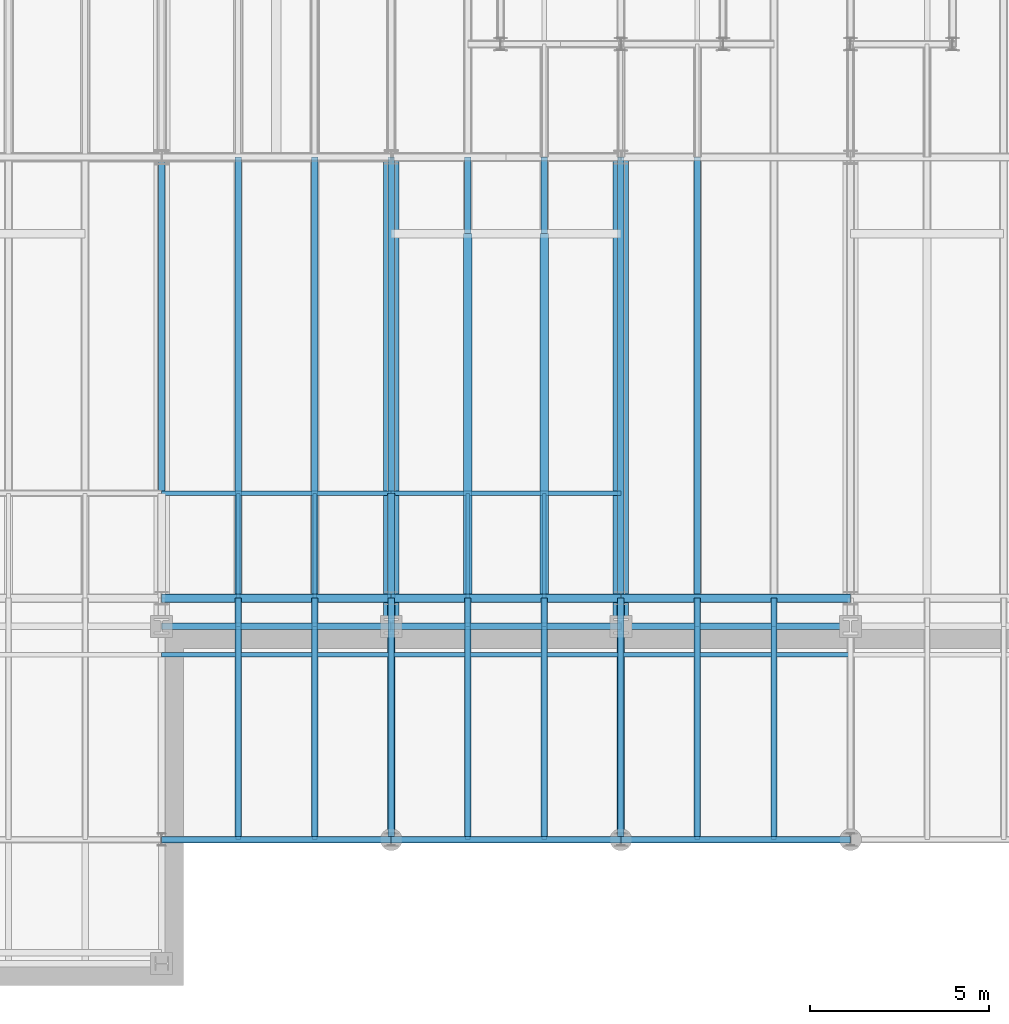
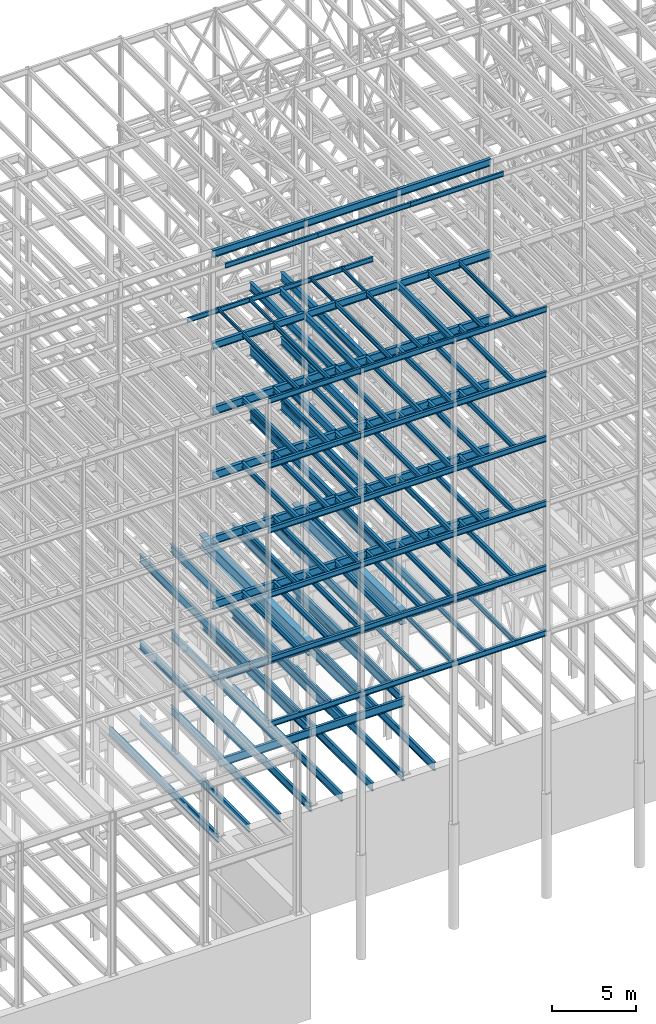
# One storey, part 130 of 150: 126 beams.
"""IFC2X3 building model written with IfcOpenShell, lengths in millimetres."""

from ifc_helpers import new_model, si_unit, frame, origin_with_axes, origin_2d_with_axis, place, context, subcontext, project, spatial, i_section, extrude, material, type_object, element, save


model = new_model("IFC2X3")

# Units and contexts
model_context = context("Model", 3, precision=1e-05, world=origin_with_axes())
body_context = subcontext(model_context, "Body", "Model", "MODEL_VIEW")
ifc_project = project(units=[si_unit("LENGTHUNIT", "METRE", prefix="MILLI"), si_unit("AREAUNIT", "SQUARE_METRE"), si_unit("VOLUMEUNIT", "CUBIC_METRE"), si_unit("MASSUNIT", "GRAM", prefix="KILO"), si_unit("TIMEUNIT", "SECOND"), si_unit("PLANEANGLEUNIT", "RADIAN"), si_unit("SOLIDANGLEUNIT", "STERADIAN"), si_unit("THERMODYNAMICTEMPERATUREUNIT", "DEGREE_CELSIUS"), si_unit("LUMINOUSINTENSITYUNIT", "LUMEN")], contexts=[model_context])

# Site, building, storey
site_placement = place(None, origin_with_axes())
site = spatial("IfcSite", under=ifc_project, at=site_placement, CompositionType="ELEMENT")
building_placement = place(site_placement, origin_with_axes())
building = spatial("IfcBuilding", under=site, at=building_placement, Name="Undefined", CompositionType="ELEMENT")
storey_placement = place(building_placement, origin_with_axes())
storey = spatial("IfcBuildingStorey", under=building, at=storey_placement, Name="Undefined", CompositionType="ELEMENT", Elevation=0.0)

# Beams
ifc_material = material(Name="STEEL/A992")
beam_type_1 = type_object("IfcBeamType", Name="W16X31", PredefinedType="NOTDEFINED")
for number, where, z_axis, x_axis, name in (
    (1, (56591.2, 3454.4, 59005.7875), (0.0, 0.0, 1.0), (1.0, 0.0, 0.0), "BEAM"),
    (2, (50190.4, 3454.4, 59005.7875), (0.0, 0.0, 1.0), (1.0, 0.0, 0.0), "BEAM"),
    (3, (43789.6, 3454.4, 59005.7875), (0.0, 0.0, 1.0), (1.0, 0.0, 0.0), "BEAM"),
):
    element("IfcBeam", number, at=place(storey_placement, frame(where, z_axis=z_axis, x_axis=x_axis)), inside=storey, type_object=beam_type_1, material=ifc_material, Name=name, ObjectType="W16X31", context=body_context, shape_type="SweptSolid", body=[
        extrude(i_section(OverallWidth=140.462, OverallDepth=403.225, WebThickness=6.3499, FlangeThickness=11.176, FilletRadius=17.399, at=origin_2d_with_axis()), frame((6400.80000000001, 0.0, 0.0), z_axis=(-1.0, 0.0, 0.0), x_axis=(0.0, -1.0, 0.0)), (0.0, 0.0, 1.0), 6400.8),
    ])
beam_type_2 = type_object("IfcBeamType", Name="W24X68", PredefinedType="NOTDEFINED")
for number, where, z_axis, x_axis, name in (
    (4, (54457.6, 10185.4, 54181.375), (0.0, 0.0, 1.0), (0.0, 1.0, 0.0), "BEAM"),
    (5, (52324.0, 10185.4, 54181.375), (0.0, 0.0, 1.0), (0.0, 1.0, 0.0), "BEAM"),
):
    element("IfcBeam", number, at=place(storey_placement, frame(where, z_axis=z_axis, x_axis=x_axis)), inside=storey, type_object=beam_type_2, material=ifc_material, Name=name, ObjectType="W24X68", context=body_context, shape_type="SweptSolid", body=[
        extrude(i_section(OverallWidth=227.838, OverallDepth=603.25, WebThickness=11.1125, FlangeThickness=14.859, FilletRadius=23.2409, at=origin_2d_with_axis()), frame((10160.0, 0.0, 0.0), z_axis=(-1.0, 0.0, 0.0), x_axis=(0.0, -1.0, 0.0)), (0.0, 0.0, 1.0), 10160.0),
    ])
for number, where, z_axis, x_axis, name in (
    (6, (56591.2, 10185.4, 54181.375), (0.0, 0.0, 1.0), (1.0, 0.0, 0.0), "BEAM"),
    (7, (50190.4, 10185.4, 54181.375), (0.0, 0.0, 1.0), (1.0, 0.0, 0.0), "BEAM"),
):
    element("IfcBeam", number, at=place(storey_placement, frame(where, z_axis=z_axis, x_axis=x_axis)), inside=storey, type_object=beam_type_2, material=ifc_material, Name=name, ObjectType="W24X68", context=body_context, shape_type="SweptSolid", body=[
        extrude(i_section(OverallWidth=227.838, OverallDepth=603.25, WebThickness=11.1125, FlangeThickness=14.859, FilletRadius=23.2409, at=origin_2d_with_axis()), frame((6400.80000000001, 0.0, 0.0), z_axis=(-1.0, 0.0, 0.0), x_axis=(0.0, -1.0, 0.0)), (0.0, 0.0, 1.0), 6400.8),
    ])
beam_1_placement = place(storey_placement, frame((43789.6, 10185.4, 54181.375), z_axis=(0.0, 0.0, 1.0), x_axis=(1.0, 0.0, 0.0)))
element("IfcBeam", 8, at=beam_1_placement, inside=storey, type_object=beam_type_2, material=ifc_material, Name="BEAM", ObjectType="W24X68", context=body_context, shape_type="SweptSolid", body=[
    extrude(i_section(OverallWidth=227.838, OverallDepth=603.25, WebThickness=11.1125, FlangeThickness=14.859, FilletRadius=23.2409, at=origin_2d_with_axis()), frame((6400.79935992001, 0.0, 0.0), z_axis=(-1.0, 0.0, 0.0), x_axis=(0.0, -1.0, 0.0)), (0.0, 0.0, 1.0), 6400.79935992),
])
for number, where, z_axis, x_axis, name in (
    (9, (54457.6, 10185.4, 49456.975), (0.0, 0.0, 1.0), (0.0, 1.0, 0.0), "BEAM"),
    (10, (52324.0, 10185.4, 49456.975), (0.0, 0.0, 1.0), (0.0, 1.0, 0.0), "BEAM"),
):
    element("IfcBeam", number, at=place(storey_placement, frame(where, z_axis=z_axis, x_axis=x_axis)), inside=storey, type_object=beam_type_2, material=ifc_material, Name=name, ObjectType="W24X68", context=body_context, shape_type="SweptSolid", body=[
        extrude(i_section(OverallWidth=227.838, OverallDepth=603.25, WebThickness=11.1125, FlangeThickness=14.859, FilletRadius=23.2409, at=origin_2d_with_axis()), frame((10160.0, 0.0, 0.0), z_axis=(-1.0, 0.0, 0.0), x_axis=(0.0, -1.0, 0.0)), (0.0, 0.0, 1.0), 10160.0),
    ])
for number, where, z_axis, x_axis, name in (
    (11, (56591.2, 10185.4, 49456.975), (0.0, 0.0, 1.0), (1.0, 0.0, 0.0), "BEAM"),
    (12, (50190.4, 10185.4, 49456.975), (0.0, 0.0, 1.0), (1.0, 0.0, 0.0), "BEAM"),
):
    element("IfcBeam", number, at=place(storey_placement, frame(where, z_axis=z_axis, x_axis=x_axis)), inside=storey, type_object=beam_type_2, material=ifc_material, Name=name, ObjectType="W24X68", context=body_context, shape_type="SweptSolid", body=[
        extrude(i_section(OverallWidth=227.838, OverallDepth=603.25, WebThickness=11.1125, FlangeThickness=14.859, FilletRadius=23.2409, at=origin_2d_with_axis()), frame((6400.80000000001, 0.0, 0.0), z_axis=(-1.0, 0.0, 0.0), x_axis=(0.0, -1.0, 0.0)), (0.0, 0.0, 1.0), 6400.8),
    ])
beam_2_placement = place(storey_placement, frame((43789.6, 10185.4, 49456.975), z_axis=(0.0, 0.0, 1.0), x_axis=(1.0, 0.0, 0.0)))
element("IfcBeam", 13, at=beam_2_placement, inside=storey, type_object=beam_type_2, material=ifc_material, Name="BEAM", ObjectType="W24X68", context=body_context, shape_type="SweptSolid", body=[
    extrude(i_section(OverallWidth=227.838, OverallDepth=603.25, WebThickness=11.1125, FlangeThickness=14.859, FilletRadius=23.2409, at=origin_2d_with_axis()), frame((6400.79935992001, 0.0, 0.0), z_axis=(-1.0, 0.0, 0.0), x_axis=(0.0, -1.0, 0.0)), (0.0, 0.0, 1.0), 6400.79935992),
])
for number, where, z_axis, x_axis, name in (
    (14, (54457.6, 10185.4, 44732.575), (0.0, 0.0, 1.0), (0.0, 1.0, 0.0), "BEAM"),
    (15, (52324.0, 10185.4, 44732.575), (0.0, 0.0, 1.0), (0.0, 1.0, 0.0), "BEAM"),
):
    element("IfcBeam", number, at=place(storey_placement, frame(where, z_axis=z_axis, x_axis=x_axis)), inside=storey, type_object=beam_type_2, material=ifc_material, Name=name, ObjectType="W24X68", context=body_context, shape_type="SweptSolid", body=[
        extrude(i_section(OverallWidth=227.838, OverallDepth=603.25, WebThickness=11.1125, FlangeThickness=14.859, FilletRadius=23.2409, at=origin_2d_with_axis()), frame((10160.0, 0.0, 0.0), z_axis=(-1.0, 0.0, 0.0), x_axis=(0.0, -1.0, 0.0)), (0.0, 0.0, 1.0), 10160.0),
    ])
for number, where, z_axis, x_axis, name in (
    (16, (56591.2, 10185.4, 44732.575), (0.0, 0.0, 1.0), (1.0, 0.0, 0.0), "BEAM"),
    (17, (50190.4, 10185.4, 44732.575), (0.0, 0.0, 1.0), (1.0, 0.0, 0.0), "BEAM"),
):
    element("IfcBeam", number, at=place(storey_placement, frame(where, z_axis=z_axis, x_axis=x_axis)), inside=storey, type_object=beam_type_2, material=ifc_material, Name=name, ObjectType="W24X68", context=body_context, shape_type="SweptSolid", body=[
        extrude(i_section(OverallWidth=227.838, OverallDepth=603.25, WebThickness=11.1125, FlangeThickness=14.859, FilletRadius=23.2409, at=origin_2d_with_axis()), frame((6400.80000000001, 0.0, 0.0), z_axis=(-1.0, 0.0, 0.0), x_axis=(0.0, -1.0, 0.0)), (0.0, 0.0, 1.0), 6400.8),
    ])
beam_3_placement = place(storey_placement, frame((43789.6, 10185.4, 44732.575), z_axis=(0.0, 0.0, 1.0), x_axis=(1.0, 0.0, 0.0)))
element("IfcBeam", 18, at=beam_3_placement, inside=storey, type_object=beam_type_2, material=ifc_material, Name="BEAM", ObjectType="W24X68", context=body_context, shape_type="SweptSolid", body=[
    extrude(i_section(OverallWidth=227.838, OverallDepth=603.25, WebThickness=11.1125, FlangeThickness=14.859, FilletRadius=23.2409, at=origin_2d_with_axis()), frame((6400.79935992001, 0.0, 0.0), z_axis=(-1.0, 0.0, 0.0), x_axis=(0.0, -1.0, 0.0)), (0.0, 0.0, 1.0), 6400.79935992),
])
for number, where, z_axis, x_axis, name in (
    (19, (56591.2, 10185.4, 40008.175), (0.0, 0.0, 1.0), (1.0, 0.0, 0.0), "BEAM"),
    (20, (50190.4, 10185.4, 40008.175), (0.0, 0.0, 1.0), (1.0, 0.0, 0.0), "BEAM"),
    (21, (43789.6, 10185.4, 40008.175), (0.0, 0.0, 1.0), (1.0, 0.0, 0.0), "BEAM"),
):
    element("IfcBeam", number, at=place(storey_placement, frame(where, z_axis=z_axis, x_axis=x_axis)), inside=storey, type_object=beam_type_2, material=ifc_material, Name=name, ObjectType="W24X68", context=body_context, shape_type="SweptSolid", body=[
        extrude(i_section(OverallWidth=227.838, OverallDepth=603.25, WebThickness=11.1125, FlangeThickness=14.859, FilletRadius=23.2409, at=origin_2d_with_axis()), frame((6400.80000000001, 0.0, 0.0), z_axis=(-1.0, 0.0, 0.0), x_axis=(0.0, -1.0, 0.0)), (0.0, 0.0, 1.0), 6400.8),
    ])
beam_type_3 = type_object("IfcBeamType", Name="W14X22", PredefinedType="NOTDEFINED")
for number, where, z_axis, x_axis, name in (
    (22, (56591.2, 8610.6, 65738.375), (0.0, 0.0, 1.0), (1.0, 0.0, 0.0), "BEAM"),
    (23, (50190.4, 8610.6, 65738.375), (0.0, 0.0, 1.0), (1.0, 0.0, 0.0), "BEAM"),
    (24, (43789.6, 8610.6, 65738.375), (0.0, 0.0, 1.0), (1.0, 0.0, 0.0), "BEAM"),
):
    element("IfcBeam", number, at=place(storey_placement, frame(where, z_axis=z_axis, x_axis=x_axis)), inside=storey, type_object=beam_type_3, material=ifc_material, Name=name, ObjectType="W14X22", context=body_context, shape_type="SweptSolid", body=[
        extrude(i_section(OverallWidth=127.0, OverallDepth=349.25, WebThickness=6.3499, FlangeThickness=8.509, FilletRadius=18.4785, at=origin_2d_with_axis()), frame((6400.80000000001, 0.0, 0.0), z_axis=(-1.0, 0.0, 0.0), x_axis=(0.0, -1.0, 0.0)), (0.0, 0.0, 1.0), 6400.8),
    ])
for number, where, z_axis, x_axis, name in (
    (25, (60858.4, 3454.4, 59032.775), (0.0, 0.0, 1.0), (0.0, 1.0, 0.0), "BEAM"),
    (26, (58724.8, 3454.4, 59032.775), (0.0, 0.0, 1.0), (0.0, 1.0, 0.0), "BEAM"),
):
    element("IfcBeam", number, at=place(storey_placement, frame(where, z_axis=z_axis, x_axis=x_axis)), inside=storey, type_object=beam_type_3, material=ifc_material, Name=name, ObjectType="W14X22", context=body_context, shape_type="SweptSolid", body=[
        extrude(i_section(OverallWidth=127.0, OverallDepth=349.25, WebThickness=6.3499, FlangeThickness=8.509, FilletRadius=18.4785, at=origin_2d_with_axis()), frame((6731.0, 0.0, 0.0), z_axis=(-1.0, 0.0, 0.0), x_axis=(0.0, -1.0, 0.0)), (0.0, 0.0, 1.0), 6731.0),
    ])
beam_4_placement = place(storey_placement, frame((50190.4, 13106.4, 59032.775), z_axis=(0.0, 0.0, 1.0), x_axis=(1.0, 0.0, 0.0)))
element("IfcBeam", 27, at=beam_4_placement, inside=storey, type_object=beam_type_3, material=ifc_material, Name="BEAM", ObjectType="W14X22", context=body_context, shape_type="SweptSolid", body=[
    extrude(i_section(OverallWidth=127.0, OverallDepth=349.25, WebThickness=6.3499, FlangeThickness=8.509, FilletRadius=18.4785, at=origin_2d_with_axis()), frame((6400.80000000001, 0.0, 0.0), z_axis=(-1.0, 0.0, 0.0), x_axis=(0.0, -1.0, 0.0)), (0.0, 0.0, 1.0), 6400.8),
])
for number, where, z_axis, x_axis, name in (
    (28, (54457.6, 3454.4, 59032.775), (0.0, 0.0, 1.0), (0.0, 1.0, 0.0), "BEAM"),
    (29, (52324.0, 3454.4, 59032.775), (0.0, 0.0, 1.0), (0.0, 1.0, 0.0), "BEAM"),
):
    element("IfcBeam", number, at=place(storey_placement, frame(where, z_axis=z_axis, x_axis=x_axis)), inside=storey, type_object=beam_type_3, material=ifc_material, Name=name, ObjectType="W14X22", context=body_context, shape_type="SweptSolid", body=[
        extrude(i_section(OverallWidth=127.0, OverallDepth=349.25, WebThickness=6.3499, FlangeThickness=8.509, FilletRadius=18.4785, at=origin_2d_with_axis()), frame((6731.0, 0.0, 0.0), z_axis=(-1.0, 0.0, 0.0), x_axis=(0.0, -1.0, 0.0)), (0.0, 0.0, 1.0), 6731.0),
    ])
beam_5_placement = place(storey_placement, frame((43789.6, 13106.4, 59032.775), z_axis=(0.0, 0.0, 1.0), x_axis=(1.0, 0.0, 0.0)))
element("IfcBeam", 30, at=beam_5_placement, inside=storey, type_object=beam_type_3, material=ifc_material, Name="BEAM", ObjectType="W14X22", context=body_context, shape_type="SweptSolid", body=[
    extrude(i_section(OverallWidth=127.0, OverallDepth=349.25, WebThickness=6.3499, FlangeThickness=8.509, FilletRadius=18.4785, at=origin_2d_with_axis()), frame((6400.80000000001, 0.0, 0.0), z_axis=(-1.0, 0.0, 0.0), x_axis=(0.0, -1.0, 0.0)), (0.0, 0.0, 1.0), 6400.8),
])
for number, where, z_axis, x_axis, name in (
    (31, (48056.8, 3454.4, 59032.775), (0.0, 0.0, 1.0), (0.0, 1.0, 0.0), "BEAM"),
    (32, (45923.2, 3454.4, 59032.775), (0.0, 0.0, 1.0), (0.0, 1.0, 0.0), "BEAM"),
):
    element("IfcBeam", number, at=place(storey_placement, frame(where, z_axis=z_axis, x_axis=x_axis)), inside=storey, type_object=beam_type_3, material=ifc_material, Name=name, ObjectType="W14X22", context=body_context, shape_type="SweptSolid", body=[
        extrude(i_section(OverallWidth=127.0, OverallDepth=349.25, WebThickness=6.3499, FlangeThickness=8.509, FilletRadius=18.4785, at=origin_2d_with_axis()), frame((6731.0, 0.0, 0.0), z_axis=(-1.0, 0.0, 0.0), x_axis=(0.0, -1.0, 0.0)), (0.0, 0.0, 1.0), 6731.0),
    ])
for number, where, z_axis, x_axis, name in (
    (33, (60858.4, 3454.4, 35410.775), (0.0, 0.0, 1.0), (0.0, 1.0, 0.0), "BEAM"),
    (34, (58724.8, 3454.4, 35410.775), (0.0, 0.0, 1.0), (0.0, 1.0, 0.0), "BEAM"),
    (35, (56591.2, 3454.4, 35410.775), (0.0, 0.0, 1.0), (0.0, 1.0, 0.0), "BEAM"),
    (36, (54457.6, 3454.4, 35410.775), (0.0, 0.0, 1.0), (0.0, 1.0, 0.0), "BEAM"),
    (37, (52324.0, 3454.4, 35410.775), (0.0, 0.0, 1.0), (0.0, 1.0, 0.0), "BEAM"),
    (38, (50190.4, 3454.4, 35410.775), (0.0, 0.0, 1.0), (0.0, 1.0, 0.0), "BEAM"),
    (39, (48056.8, 3454.4, 35410.775), (0.0, 0.0, 1.0), (0.0, 1.0, 0.0), "BEAM"),
    (40, (45923.2, 3454.4, 35410.775), (0.0, 0.0, 1.0), (0.0, 1.0, 0.0), "BEAM"),
):
    element("IfcBeam", number, at=place(storey_placement, frame(where, z_axis=z_axis, x_axis=x_axis)), inside=storey, type_object=beam_type_3, material=ifc_material, Name=name, ObjectType="W14X22", context=body_context, shape_type="SweptSolid", body=[
        extrude(i_section(OverallWidth=127.0, OverallDepth=349.25, WebThickness=6.3499, FlangeThickness=8.509, FilletRadius=18.4785, at=origin_2d_with_axis()), frame((5943.6, 0.0, 0.0), z_axis=(-1.0, 0.0, 0.0), x_axis=(0.0, -1.0, 0.0)), (0.0, 0.0, 1.0), 5943.6),
    ])
beam_type_4 = type_object("IfcBeamType", Name="W21X55", PredefinedType="NOTDEFINED")
for number, where, z_axis, x_axis, name in (
    (41, (56591.2, 10185.4, 65649.475), (0.0, 0.0, 1.0), (1.0, 0.0, 0.0), "BEAM"),
    (42, (50190.4, 10185.4, 65649.475), (0.0, 0.0, 1.0), (1.0, 0.0, 0.0), "BEAM"),
    (43, (43789.6, 10185.4, 65649.475), (0.0, 0.0, 1.0), (1.0, 0.0, 0.0), "BEAM"),
    (44, (56591.2, 10185.4, 58943.875), (0.0, 0.0, 1.0), (1.0, 0.0, 0.0), "BEAM"),
):
    element("IfcBeam", number, at=place(storey_placement, frame(where, z_axis=z_axis, x_axis=x_axis)), inside=storey, type_object=beam_type_4, material=ifc_material, Name=name, ObjectType="W21X55", context=body_context, shape_type="SweptSolid", body=[
        extrude(i_section(OverallWidth=208.788, OverallDepth=527.05, WebThickness=9.5, FlangeThickness=13.2588, FilletRadius=16.8624, at=origin_2d_with_axis()), frame((6400.80000000001, 0.0, 0.0), z_axis=(-1.0, 0.0, 0.0), x_axis=(0.0, -1.0, 0.0)), (0.0, 0.0, 1.0), 6400.8),
    ])
beam_6_placement = place(storey_placement, frame((56591.2, 3454.4, 58943.875), z_axis=(0.0, 0.0, 1.0), x_axis=(0.0, 1.0, 0.0)))
element("IfcBeam", 45, at=beam_6_placement, inside=storey, type_object=beam_type_4, material=ifc_material, Name="BEAM", ObjectType="W21X55", context=body_context, shape_type="SweptSolid", body=[
    extrude(i_section(OverallWidth=208.788, OverallDepth=527.05, WebThickness=9.5, FlangeThickness=13.2588, FilletRadius=16.8624, at=origin_2d_with_axis()), frame((6731.0, 0.0, 0.0), z_axis=(-1.0, 0.0, 0.0), x_axis=(0.0, -1.0, 0.0)), (0.0, 0.0, 1.0), 6731.0),
])
beam_7_placement = place(storey_placement, frame((50190.4, 10185.4, 58943.875), z_axis=(0.0, 0.0, 1.0), x_axis=(1.0, 0.0, 0.0)))
element("IfcBeam", 46, at=beam_7_placement, inside=storey, type_object=beam_type_4, material=ifc_material, Name="BEAM", ObjectType="W21X55", context=body_context, shape_type="SweptSolid", body=[
    extrude(i_section(OverallWidth=208.788, OverallDepth=527.05, WebThickness=9.5, FlangeThickness=13.2588, FilletRadius=16.8624, at=origin_2d_with_axis()), frame((6400.80000000001, 0.0, 0.0), z_axis=(-1.0, 0.0, 0.0), x_axis=(0.0, -1.0, 0.0)), (0.0, 0.0, 1.0), 6400.8),
])
beam_8_placement = place(storey_placement, frame((50190.4, 10185.4, 58943.875), z_axis=(0.0, 0.0, 1.0), x_axis=(0.0, 1.0, 0.0)))
element("IfcBeam", 47, at=beam_8_placement, inside=storey, type_object=beam_type_4, material=ifc_material, Name="BEAM", ObjectType="W21X55", context=body_context, shape_type="SweptSolid", body=[
    extrude(i_section(OverallWidth=208.788, OverallDepth=527.05, WebThickness=9.5, FlangeThickness=13.2588, FilletRadius=16.8624, at=origin_2d_with_axis()), frame((2921.0, 0.0, 0.0), z_axis=(-1.0, 0.0, 0.0), x_axis=(0.0, -1.0, 0.0)), (0.0, 0.0, 1.0), 2921.0),
])
beam_9_placement = place(storey_placement, frame((50190.4, 3454.4, 58943.875), z_axis=(0.0, 0.0, 1.0), x_axis=(0.0, 1.0, 0.0)))
element("IfcBeam", 48, at=beam_9_placement, inside=storey, type_object=beam_type_4, material=ifc_material, Name="BEAM", ObjectType="W21X55", context=body_context, shape_type="SweptSolid", body=[
    extrude(i_section(OverallWidth=208.788, OverallDepth=527.05, WebThickness=9.5, FlangeThickness=13.2588, FilletRadius=16.8624, at=origin_2d_with_axis()), frame((6731.0, 0.0, 0.0), z_axis=(-1.0, 0.0, 0.0), x_axis=(0.0, -1.0, 0.0)), (0.0, 0.0, 1.0), 6731.0),
])
beam_10_placement = place(storey_placement, frame((43789.6, 10185.4, 58943.875), z_axis=(0.0, 0.0, 1.0), x_axis=(1.0, 0.0, 0.0)))
element("IfcBeam", 49, at=beam_10_placement, inside=storey, type_object=beam_type_4, material=ifc_material, Name="BEAM", ObjectType="W21X55", context=body_context, shape_type="SweptSolid", body=[
    extrude(i_section(OverallWidth=208.788, OverallDepth=527.05, WebThickness=9.5, FlangeThickness=13.2588, FilletRadius=16.8624, at=origin_2d_with_axis()), frame((6400.80000000001, 0.0, 0.0), z_axis=(-1.0, 0.0, 0.0), x_axis=(0.0, -1.0, 0.0)), (0.0, 0.0, 1.0), 6400.8),
])
beam_type_5 = type_object("IfcBeamType", Name="W10X15", PredefinedType="NOTDEFINED")
for number, where, z_axis, x_axis, name in (
    (50, (54457.6, 10185.4, 59080.4), (0.0, 0.0, 1.0), (0.0, 1.0, 0.0), "BEAM"),
    (51, (52324.0, 10185.4, 59080.4), (0.0, 0.0, 1.0), (0.0, 1.0, 0.0), "BEAM"),
    (52, (48056.8, 10185.4, 59080.4), (0.0, 0.0, 1.0), (0.0, 1.0, 0.0), "BEAM"),
    (53, (45923.2, 10185.4, 59080.4), (0.0, 0.0, 1.0), (0.0, 1.0, 0.0), "BEAM"),
):
    element("IfcBeam", number, at=place(storey_placement, frame(where, z_axis=z_axis, x_axis=x_axis)), inside=storey, type_object=beam_type_5, material=ifc_material, Name=name, ObjectType="W10X15", context=body_context, shape_type="SweptSolid", body=[
        extrude(i_section(OverallWidth=101.6, OverallDepth=254.0, WebThickness=6.3499, FlangeThickness=6.858, FilletRadius=13.7795, at=origin_2d_with_axis()), frame((2921.0, 0.0, 0.0), z_axis=(-1.0, 0.0, 0.0), x_axis=(0.0, -1.0, 0.0)), (0.0, 0.0, 1.0), 2921.0),
    ])
beam_type_6 = type_object("IfcBeamType", Name="W24X55", PredefinedType="NOTDEFINED")
for number, where, z_axis, x_axis, name in (
    (54, (56591.2, 9398.0, 35285.3625), (0.0, 0.0, 1.0), (1.0, 0.0, 0.0), "BEAM"),
    (55, (50190.4, 9398.0, 35285.3625), (0.0, 0.0, 1.0), (1.0, 0.0, 0.0), "BEAM"),
    (56, (43789.6, 9398.0, 35285.3625), (0.0, 0.0, 1.0), (1.0, 0.0, 0.0), "BEAM"),
):
    element("IfcBeam", number, at=place(storey_placement, frame(where, z_axis=z_axis, x_axis=x_axis)), inside=storey, type_object=beam_type_6, material=ifc_material, Name=name, ObjectType="W24X55", context=body_context, shape_type="SweptSolid", body=[
        extrude(i_section(OverallWidth=178.054, OverallDepth=600.075, WebThickness=9.5249, FlangeThickness=12.827, FilletRadius=23.6854, at=origin_2d_with_axis()), frame((6400.80000000001, 0.0, 0.0), z_axis=(-1.0, 0.0, 0.0), x_axis=(0.0, -1.0, 0.0)), (0.0, 0.0, 1.0), 6400.8),
    ])
beam_type_7 = type_object("IfcBeamType", Name="W16X36", PredefinedType="NOTDEFINED")
for number, where, z_axis, x_axis, name in (
    (57, (56591.2, 3454.4, 54281.3875), (0.0, 0.0, 1.0), (1.0, 0.0, 0.0), "BEAM"),
    (58, (50190.4, 3454.4, 54281.3875), (0.0, 0.0, 1.0), (1.0, 0.0, 0.0), "BEAM"),
    (59, (43789.6, 3454.4, 54281.3875), (0.0, 0.0, 1.0), (1.0, 0.0, 0.0), "BEAM"),
):
    element("IfcBeam", number, at=place(storey_placement, frame(where, z_axis=z_axis, x_axis=x_axis)), inside=storey, type_object=beam_type_7, material=ifc_material, Name=name, ObjectType="W16X36", context=body_context, shape_type="SweptSolid", body=[
        extrude(i_section(OverallWidth=177.8, OverallDepth=403.225, WebThickness=7.9375, FlangeThickness=10.922, FilletRadius=17.6529, at=origin_2d_with_axis()), frame((6400.80000000001, 0.0, 0.0), z_axis=(-1.0, 0.0, 0.0), x_axis=(0.0, -1.0, 0.0)), (0.0, 0.0, 1.0), 6400.8),
    ])
for number, where, z_axis, x_axis, name in (
    (60, (60858.4, 3454.4, 54281.3875), (0.0, 0.0, 1.0), (0.0, 1.0, 0.0), "BEAM"),
    (61, (58724.8, 3454.4, 54281.3875), (0.0, 0.0, 1.0), (0.0, 1.0, 0.0), "BEAM"),
    (62, (56591.2, 3454.4, 54281.3875), (0.0, 0.0, 1.0), (0.0, 1.0, 0.0), "BEAM"),
    (63, (54457.6, 3454.4, 54281.3875), (0.0, 0.0, 1.0), (0.0, 1.0, 0.0), "BEAM"),
    (64, (52324.0, 3454.4, 54281.3875), (0.0, 0.0, 1.0), (0.0, 1.0, 0.0), "BEAM"),
    (65, (50190.4, 3454.4, 54281.3875), (0.0, 0.0, 1.0), (0.0, 1.0, 0.0), "BEAM"),
    (66, (48056.8, 3454.4, 54281.3875), (0.0, 0.0, 1.0), (0.0, 1.0, 0.0), "BEAM"),
    (67, (45923.2, 3454.4, 54281.3875), (0.0, 0.0, 1.0), (0.0, 1.0, 0.0), "BEAM"),
):
    element("IfcBeam", number, at=place(storey_placement, frame(where, z_axis=z_axis, x_axis=x_axis)), inside=storey, type_object=beam_type_7, material=ifc_material, Name=name, ObjectType="W16X36", context=body_context, shape_type="SweptSolid", body=[
        extrude(i_section(OverallWidth=177.8, OverallDepth=403.225, WebThickness=7.9375, FlangeThickness=10.922, FilletRadius=17.6529, at=origin_2d_with_axis()), frame((6731.0, 0.0, 0.0), z_axis=(-1.0, 0.0, 0.0), x_axis=(0.0, -1.0, 0.0)), (0.0, 0.0, 1.0), 6731.0),
    ])
for number, where, z_axis, x_axis, name in (
    (68, (56591.2, 3454.4, 49556.9875), (0.0, 0.0, 1.0), (1.0, 0.0, 0.0), "BEAM"),
    (69, (50190.4, 3454.4, 49556.9875), (0.0, 0.0, 1.0), (1.0, 0.0, 0.0), "BEAM"),
    (70, (43789.6, 3454.4, 49556.9875), (0.0, 0.0, 1.0), (1.0, 0.0, 0.0), "BEAM"),
):
    element("IfcBeam", number, at=place(storey_placement, frame(where, z_axis=z_axis, x_axis=x_axis)), inside=storey, type_object=beam_type_7, material=ifc_material, Name=name, ObjectType="W16X36", context=body_context, shape_type="SweptSolid", body=[
        extrude(i_section(OverallWidth=177.8, OverallDepth=403.225, WebThickness=7.9375, FlangeThickness=10.922, FilletRadius=17.6529, at=origin_2d_with_axis()), frame((6400.80000000001, 0.0, 0.0), z_axis=(-1.0, 0.0, 0.0), x_axis=(0.0, -1.0, 0.0)), (0.0, 0.0, 1.0), 6400.8),
    ])
for number, where, z_axis, x_axis, name in (
    (71, (60858.4, 3454.4, 49556.9875), (0.0, 0.0, 1.0), (0.0, 1.0, 0.0), "BEAM"),
    (72, (58724.8, 3454.4, 49556.9875), (0.0, 0.0, 1.0), (0.0, 1.0, 0.0), "BEAM"),
    (73, (56591.2, 3454.4, 49556.9875), (0.0, 0.0, 1.0), (0.0, 1.0, 0.0), "BEAM"),
    (74, (54457.6, 3454.4, 49556.9875), (0.0, 0.0, 1.0), (0.0, 1.0, 0.0), "BEAM"),
    (75, (52324.0, 3454.4, 49556.9875), (0.0, 0.0, 1.0), (0.0, 1.0, 0.0), "BEAM"),
    (76, (50190.4, 3454.4, 49556.9875), (0.0, 0.0, 1.0), (0.0, 1.0, 0.0), "BEAM"),
    (77, (48056.8, 3454.4, 49556.9875), (0.0, 0.0, 1.0), (0.0, 1.0, 0.0), "BEAM"),
    (78, (45923.2, 3454.4, 49556.9875), (0.0, 0.0, 1.0), (0.0, 1.0, 0.0), "BEAM"),
):
    element("IfcBeam", number, at=place(storey_placement, frame(where, z_axis=z_axis, x_axis=x_axis)), inside=storey, type_object=beam_type_7, material=ifc_material, Name=name, ObjectType="W16X36", context=body_context, shape_type="SweptSolid", body=[
        extrude(i_section(OverallWidth=177.8, OverallDepth=403.225, WebThickness=7.9375, FlangeThickness=10.922, FilletRadius=17.6529, at=origin_2d_with_axis()), frame((6731.0, 0.0, 0.0), z_axis=(-1.0, 0.0, 0.0), x_axis=(0.0, -1.0, 0.0)), (0.0, 0.0, 1.0), 6731.0),
    ])
for number, where, z_axis, x_axis, name in (
    (79, (56591.2, 3454.4, 44832.5875), (0.0, 0.0, 1.0), (1.0, 0.0, 0.0), "BEAM"),
    (80, (50190.4, 3454.4, 44832.5875), (0.0, 0.0, 1.0), (1.0, 0.0, 0.0), "BEAM"),
    (81, (43789.6, 3454.4, 44832.5875), (0.0, 0.0, 1.0), (1.0, 0.0, 0.0), "BEAM"),
):
    element("IfcBeam", number, at=place(storey_placement, frame(where, z_axis=z_axis, x_axis=x_axis)), inside=storey, type_object=beam_type_7, material=ifc_material, Name=name, ObjectType="W16X36", context=body_context, shape_type="SweptSolid", body=[
        extrude(i_section(OverallWidth=177.8, OverallDepth=403.225, WebThickness=7.9375, FlangeThickness=10.922, FilletRadius=17.6529, at=origin_2d_with_axis()), frame((6400.80000000001, 0.0, 0.0), z_axis=(-1.0, 0.0, 0.0), x_axis=(0.0, -1.0, 0.0)), (0.0, 0.0, 1.0), 6400.8),
    ])
for number, where, z_axis, x_axis, name in (
    (82, (60858.4, 3454.4, 44832.5875), (0.0, 0.0, 1.0), (0.0, 1.0, 0.0), "BEAM"),
    (83, (58724.8, 3454.4, 44832.5875), (0.0, 0.0, 1.0), (0.0, 1.0, 0.0), "BEAM"),
    (84, (56591.2, 3454.4, 44832.5875), (0.0, 0.0, 1.0), (0.0, 1.0, 0.0), "BEAM"),
    (85, (54457.6, 3454.4, 44832.5875), (0.0, 0.0, 1.0), (0.0, 1.0, 0.0), "BEAM"),
    (86, (52324.0, 3454.4, 44832.5875), (0.0, 0.0, 1.0), (0.0, 1.0, 0.0), "BEAM"),
    (87, (50190.4, 3454.4, 44832.5875), (0.0, 0.0, 1.0), (0.0, 1.0, 0.0), "BEAM"),
    (88, (48056.8, 3454.4, 44832.5875), (0.0, 0.0, 1.0), (0.0, 1.0, 0.0), "BEAM"),
    (89, (45923.2, 3454.4, 44832.5875), (0.0, 0.0, 1.0), (0.0, 1.0, 0.0), "BEAM"),
):
    element("IfcBeam", number, at=place(storey_placement, frame(where, z_axis=z_axis, x_axis=x_axis)), inside=storey, type_object=beam_type_7, material=ifc_material, Name=name, ObjectType="W16X36", context=body_context, shape_type="SweptSolid", body=[
        extrude(i_section(OverallWidth=177.8, OverallDepth=403.225, WebThickness=7.9375, FlangeThickness=10.922, FilletRadius=17.6529, at=origin_2d_with_axis()), frame((6731.0, 0.0, 0.0), z_axis=(-1.0, 0.0, 0.0), x_axis=(0.0, -1.0, 0.0)), (0.0, 0.0, 1.0), 6731.0),
    ])
for number, where, z_axis, x_axis, name in (
    (90, (56591.2, 3454.4, 40108.1875), (0.0, 0.0, 1.0), (1.0, 0.0, 0.0), "BEAM"),
    (91, (50190.4, 3454.4, 40108.1875), (0.0, 0.0, 1.0), (1.0, 0.0, 0.0), "BEAM"),
    (92, (43789.6, 3454.4, 40108.1875), (0.0, 0.0, 1.0), (1.0, 0.0, 0.0), "BEAM"),
):
    element("IfcBeam", number, at=place(storey_placement, frame(where, z_axis=z_axis, x_axis=x_axis)), inside=storey, type_object=beam_type_7, material=ifc_material, Name=name, ObjectType="W16X36", context=body_context, shape_type="SweptSolid", body=[
        extrude(i_section(OverallWidth=177.8, OverallDepth=403.225, WebThickness=7.9375, FlangeThickness=10.922, FilletRadius=17.6529, at=origin_2d_with_axis()), frame((6400.80000000001, 0.0, 0.0), z_axis=(-1.0, 0.0, 0.0), x_axis=(0.0, -1.0, 0.0)), (0.0, 0.0, 1.0), 6400.8),
    ])
for number, where, z_axis, x_axis, name in (
    (93, (60858.4, 3454.4, 40108.1875), (0.0, 0.0, 1.0), (0.0, 1.0, 0.0), "BEAM"),
    (94, (58724.8, 3454.4, 40108.1875), (0.0, 0.0, 1.0), (0.0, 1.0, 0.0), "BEAM"),
    (95, (56591.2, 3454.4, 40108.1875), (0.0, 0.0, 1.0), (0.0, 1.0, 0.0), "BEAM"),
    (96, (54457.6, 3454.4, 40108.1875), (0.0, 0.0, 1.0), (0.0, 1.0, 0.0), "BEAM"),
    (97, (52324.0, 3454.4, 40108.1875), (0.0, 0.0, 1.0), (0.0, 1.0, 0.0), "BEAM"),
    (98, (50190.4, 3454.4, 40108.1875), (0.0, 0.0, 1.0), (0.0, 1.0, 0.0), "BEAM"),
    (99, (48056.8, 3454.4, 40108.1875), (0.0, 0.0, 1.0), (0.0, 1.0, 0.0), "BEAM"),
    (100, (45923.2, 3454.4, 40108.1875), (0.0, 0.0, 1.0), (0.0, 1.0, 0.0), "BEAM"),
):
    element("IfcBeam", number, at=place(storey_placement, frame(where, z_axis=z_axis, x_axis=x_axis)), inside=storey, type_object=beam_type_7, material=ifc_material, Name=name, ObjectType="W16X36", context=body_context, shape_type="SweptSolid", body=[
        extrude(i_section(OverallWidth=177.8, OverallDepth=403.225, WebThickness=7.9375, FlangeThickness=10.922, FilletRadius=17.6529, at=origin_2d_with_axis()), frame((6731.0, 0.0, 0.0), z_axis=(-1.0, 0.0, 0.0), x_axis=(0.0, -1.0, 0.0)), (0.0, 0.0, 1.0), 6731.0),
    ])
beam_11_placement = place(storey_placement, frame((56591.2, 3454.4, 35383.7875), z_axis=(0.0, 0.0, 1.0), x_axis=(1.0, 0.0, 0.0)))
element("IfcBeam", 101, at=beam_11_placement, inside=storey, type_object=beam_type_7, material=ifc_material, Name="BEAM", ObjectType="W16X36", context=body_context, shape_type="SweptSolid", body=[
    extrude(i_section(OverallWidth=177.8, OverallDepth=403.225, WebThickness=7.9375, FlangeThickness=10.922, FilletRadius=17.6529, at=origin_2d_with_axis()), frame((6400.80000000001, 0.0, 0.0), z_axis=(-1.0, 0.0, 0.0), x_axis=(0.0, -1.0, 0.0)), (0.0, 0.0, 1.0), 6400.80000000001),
])
for number, where, z_axis, x_axis, name in (
    (102, (50190.4, 3454.4, 35383.7875), (0.0, 0.0, 1.0), (1.0, 0.0, 0.0), "BEAM"),
    (103, (43789.6, 3454.4, 35383.7875), (0.0, 0.0, 1.0), (1.0, 0.0, 0.0), "BEAM"),
):
    element("IfcBeam", number, at=place(storey_placement, frame(where, z_axis=z_axis, x_axis=x_axis)), inside=storey, type_object=beam_type_7, material=ifc_material, Name=name, ObjectType="W16X36", context=body_context, shape_type="SweptSolid", body=[
        extrude(i_section(OverallWidth=177.8, OverallDepth=403.225, WebThickness=7.9375, FlangeThickness=10.922, FilletRadius=17.6529, at=origin_2d_with_axis()), frame((6400.80000000001, 0.0, 0.0), z_axis=(-1.0, 0.0, 0.0), x_axis=(0.0, -1.0, 0.0)), (0.0, 0.0, 1.0), 6400.8),
    ])
beam_type_8 = type_object("IfcBeamType", Name="W24X62", PredefinedType="NOTDEFINED")
for number, where, z_axis, x_axis, name in (
    (104, (58724.8, 9398.0, 35283.775), (0.0, 0.0, 1.0), (0.0, 1.0, 0.0), "BEAM"),
    (105, (54457.6, 9398.0, 35283.775), (0.0, 0.0, 1.0), (0.0, 1.0, 0.0), "BEAM"),
    (106, (52324.0, 9398.0, 35283.775), (0.0, 0.0, 1.0), (0.0, 1.0, 0.0), "BEAM"),
    (107, (48056.8, 9398.0, 35283.775), (0.0, 0.0, 1.0), (0.0, 1.0, 0.0), "BEAM"),
    (108, (45923.2, 9398.0, 35283.775), (0.0, 0.0, 1.0), (0.0, 1.0, 0.0), "BEAM"),
    (109, (56591.2, 9398.0, 28984.575), (0.0, 0.0, 1.0), (0.0, 1.0, 0.0), "BEAM"),
    (110, (54457.6, 9398.0, 28984.575), (0.0, 0.0, 1.0), (0.0, 1.0, 0.0), "BEAM"),
    (111, (52324.0, 9398.0, 28984.575), (0.0, 0.0, 1.0), (0.0, 1.0, 0.0), "BEAM"),
    (112, (50190.4, 9398.0, 28984.575), (0.0, 0.0, 1.0), (0.0, 1.0, 0.0), "BEAM"),
    (113, (48056.8, 9398.0, 28984.575), (0.0, 0.0, 1.0), (0.0, 1.0, 0.0), "BEAM"),
    (114, (45923.2, 9398.0, 28984.575), (0.0, 0.0, 1.0), (0.0, 1.0, 0.0), "BEAM"),
):
    element("IfcBeam", number, at=place(storey_placement, frame(where, z_axis=z_axis, x_axis=x_axis)), inside=storey, type_object=beam_type_8, material=ifc_material, Name=name, ObjectType="W24X62", context=body_context, shape_type="SweptSolid", body=[
        extrude(i_section(OverallWidth=177.8, OverallDepth=603.25, WebThickness=11.1125, FlangeThickness=14.986, FilletRadius=23.114, at=origin_2d_with_axis()), frame((13081.0, 0.0, 0.0), z_axis=(-1.0, 0.0, 0.0), x_axis=(0.0, -1.0, 0.0)), (0.0, 0.0, 1.0), 13081.0),
    ])
beam_12_placement = place(storey_placement, frame((50190.4, 9398.0, 28984.575), z_axis=(0.0, 0.0, 1.0), x_axis=(1.0, 0.0, 0.0)))
element("IfcBeam", 115, at=beam_12_placement, inside=storey, type_object=beam_type_8, material=ifc_material, Name="BEAM", ObjectType="W24X62", context=body_context, shape_type="SweptSolid", body=[
    extrude(i_section(OverallWidth=177.8, OverallDepth=603.25, WebThickness=11.1125, FlangeThickness=14.986, FilletRadius=23.114, at=origin_2d_with_axis()), frame((6400.80000000001, 0.0, 0.0), z_axis=(-1.0, 0.0, 0.0), x_axis=(0.0, -1.0, 0.0)), (0.0, 0.0, 1.0), 6400.8),
])
beam_13_placement = place(storey_placement, frame((43789.6, 9398.0, 28984.575), z_axis=(0.0, 0.0, 1.0), x_axis=(1.0, 0.0, 0.0)))
element("IfcBeam", 116, at=beam_13_placement, inside=storey, type_object=beam_type_8, material=ifc_material, Name="BEAM", ObjectType="W24X62", context=body_context, shape_type="SweptSolid", body=[
    extrude(i_section(OverallWidth=177.8, OverallDepth=603.25, WebThickness=11.1125, FlangeThickness=14.986, FilletRadius=23.114, at=origin_2d_with_axis()), frame((6400.80000000001, 0.0, 0.0), z_axis=(-1.0, 0.0, 0.0), x_axis=(0.0, -1.0, 0.0)), (0.0, 0.0, 1.0), 6400.80000000001),
])
for number, where, z_axis, x_axis, name in (
    (117, (48056.8, 9398.0, 23472.775), (0.0, 0.0, 1.0), (0.0, 1.0, 0.0), "BEAM"),
    (118, (45923.2, 9398.0, 23472.775), (0.0, 0.0, 1.0), (0.0, 1.0, 0.0), "BEAM"),
    (119, (58724.8, 9398.0, 23472.775), (0.0, 0.0, 1.0), (0.0, 1.0, 0.0), "BEAM"),
    (120, (56591.2, 9398.0, 23472.775), (0.0, 0.0, 1.0), (0.0, 1.0, 0.0), "BEAM"),
    (121, (54457.6, 9398.0, 23472.775), (0.0, 0.0, 1.0), (0.0, 1.0, 0.0), "BEAM"),
    (122, (52324.0, 9398.0, 23472.775), (0.0, 0.0, 1.0), (0.0, 1.0, 0.0), "BEAM"),
    (123, (50190.4, 9398.0, 23472.775), (0.0, 0.0, 1.0), (0.0, 1.0, 0.0), "BEAM"),
    (124, (43789.6, 9398.0, 23472.775), (0.0, 0.0, 1.0), (0.0, 1.0, 0.0), "BEAM"),
):
    element("IfcBeam", number, at=place(storey_placement, frame(where, z_axis=z_axis, x_axis=x_axis)), inside=storey, type_object=beam_type_8, material=ifc_material, Name=name, ObjectType="W24X62", context=body_context, shape_type="SweptSolid", body=[
        extrude(i_section(OverallWidth=177.8, OverallDepth=603.25, WebThickness=11.1125, FlangeThickness=14.986, FilletRadius=23.114, at=origin_2d_with_axis()), frame((13081.0, 0.0, 0.0), z_axis=(-1.0, 0.0, 0.0), x_axis=(0.0, -1.0, 0.0)), (0.0, 0.0, 1.0), 13081.0),
    ])
beam_type_9 = type_object("IfcBeamType", Name="W36X395", PredefinedType="NOTDEFINED")
for number, where, z_axis, x_axis, name in (
    (125, (56591.2, 9398.0, 35098.0375), (0.0, 0.0, 1.0), (0.0, 1.0, 0.0), "BEAM"),
    (126, (50190.4, 9398.0, 35098.0375), (0.0, 0.0, 1.0), (0.0, 1.0, 0.0), "BEAM"),
):
    element("IfcBeam", number, at=place(storey_placement, frame(where, z_axis=z_axis, x_axis=x_axis)), inside=storey, type_object=beam_type_9, material=ifc_material, Name=name, ObjectType="W36X395", context=body_context, shape_type="SweptSolid", body=[
        extrude(i_section(OverallWidth=428.625, OverallDepth=974.725, WebThickness=30.988, FlangeThickness=55.88, FilletRadius=31.4324, at=origin_2d_with_axis()), frame((13081.0, 0.0, 0.0), z_axis=(-1.0, 0.0, 0.0), x_axis=(0.0, -1.0, 0.0)), (0.0, 0.0, 1.0), 13081.0),
    ])

save(model, "model.ifc")
